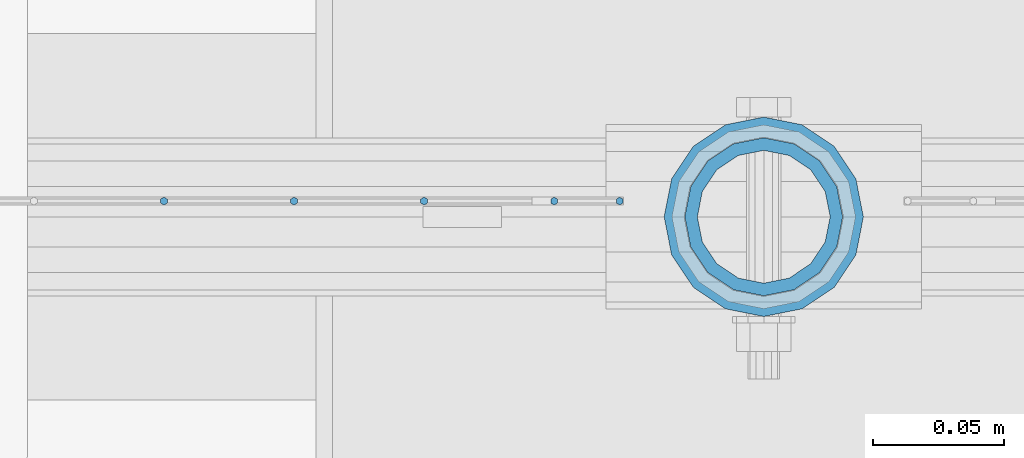
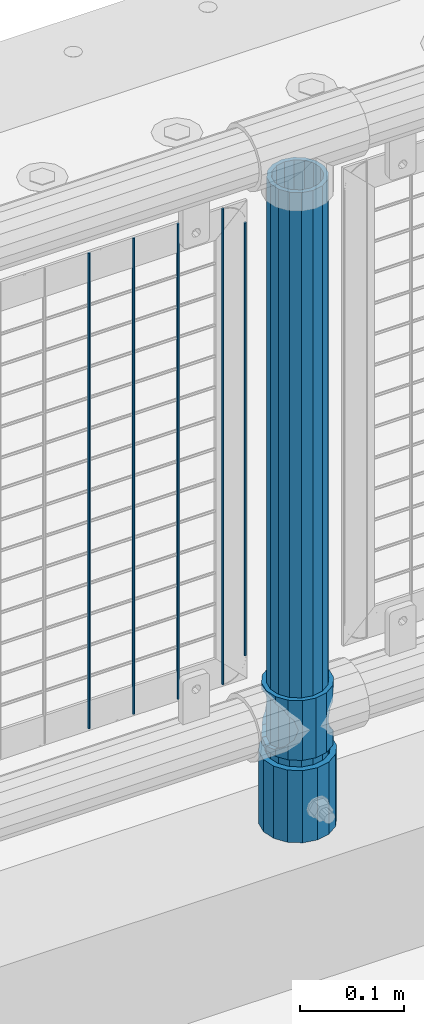
# One storey, part 57 of 208: 8 columns.
"""IFC2X3 building model written with IfcOpenShell, lengths in millimetres."""

from ifc_helpers import new_model, si_unit, frame, origin_with_axes, place, context, subcontext, project, spatial, faceted_brep, material, type_object, element, save


model = new_model("IFC2X3")

# Units and contexts
model_context = context("Model", 3, precision=1e-05, world=origin_with_axes())
body_context = subcontext(model_context, "Body", "Model", "MODEL_VIEW")
ifc_project = project(units=[si_unit("LENGTHUNIT", "METRE", prefix="MILLI"), si_unit("AREAUNIT", "SQUARE_METRE"), si_unit("VOLUMEUNIT", "CUBIC_METRE"), si_unit("MASSUNIT", "GRAM", prefix="KILO"), si_unit("TIMEUNIT", "SECOND"), si_unit("PLANEANGLEUNIT", "RADIAN"), si_unit("SOLIDANGLEUNIT", "STERADIAN"), si_unit("THERMODYNAMICTEMPERATUREUNIT", "DEGREE_CELSIUS"), si_unit("LUMINOUSINTENSITYUNIT", "LUMEN")], contexts=[model_context])

# Site, building, storey
site_placement = place(None, origin_with_axes())
site = spatial("IfcSite", under=ifc_project, at=site_placement, CompositionType="ELEMENT")
building_placement = place(site_placement, origin_with_axes())
building = spatial("IfcBuilding", under=site, at=building_placement, Name="Standard", CompositionType="ELEMENT")
storey_placement = place(building_placement, origin_with_axes())
storey = spatial("IfcBuildingStorey", under=building, at=storey_placement, Name="Undefined", CompositionType="ELEMENT", Elevation=0.0)

# Columns
ifc_material_1 = material()
column_type_1 = type_object("IfcColumnType", PredefinedType="NOTDEFINED")
column_1_placement = place(storey_placement, frame((-40229.0, 4664.5, 168.02), z_axis=(0.0, 1.0, 0.0), x_axis=(0.0, 0.0, 1.0)))
element("IfcColumn", 1, at=column_1_placement, inside=storey, type_object=column_type_1, material=ifc_material_1, context=body_context, shape_type="Brep", body=[
    faceted_brep([(0.0, -31.75, 0.0), (0.0, -29.3331751572332, 12.1501989775916), (85.0, -29.3331751572332, 12.1501989775916), (85.0, -31.75, 0.0), (0.0, -22.4506403026717, 22.4506403026726), (85.0, -22.4506403026717, 22.4506403026726), (0.0, -12.1501989775934, 29.3331751572332), (85.0, -12.1501989775934, 29.3331751572332), (0.0, 0.0, 31.75), (85.0, 0.0, 31.75), (0.0, 12.1501989775934, 29.3331751572332), (85.0, 12.1501989775934, 29.3331751572332), (0.0, 22.4506403026717, 22.4506403026726), (85.0, 22.4506403026717, 22.4506403026726), (0.0, 29.3331751572332, 12.1501989775916), (85.0, 29.3331751572332, 12.1501989775916), (0.0, 31.75, 0.0), (85.0, 31.75, 0.0), (0.0, 29.3331751572332, -12.1501989775916), (85.0, 29.3331751572332, -12.1501989775916), (0.0, 22.4506403026717, -22.4506403026726), (85.0, 22.4506403026717, -22.4506403026726), (0.0, 12.1501989775934, -29.3331751572332), (85.0, 12.1501989775934, -29.3331751572332), (0.0, 0.0, -31.75), (85.0, 0.0, -31.75), (0.0, -12.1501989775934, -29.3331751572332), (85.0, -12.1501989775934, -29.3331751572332), (0.0, -22.4506403026717, -22.4506403026726), (85.0, -22.4506403026717, -22.4506403026726), (0.0, -29.3331751572332, -12.1501989775916), (85.0, -29.3331751572332, -12.1501989775916), (0.0, -38.0499999999993, 0.0), (0.0, -35.1536162120537, -14.5611046014919), (85.0, -35.1536162120537, -14.5611046014919), (85.0, -38.0499999999993, 0.0), (0.0, -26.9054130241493, -26.9054130241484), (85.0, -26.9054130241493, -26.9054130241484), (0.0, -14.5611046014928, -35.1536162120547), (85.0, -14.5611046014928, -35.1536162120547), (0.0, 0.0, -38.0500000000002), (85.0, 0.0, -38.0500000000002), (0.0, 14.5611046014928, -35.1536162120547), (85.0, 14.5611046014928, -35.1536162120547), (0.0, 26.9054130241493, -26.9054130241484), (85.0, 26.9054130241493, -26.9054130241484), (0.0, 35.1536162120537, -14.5611046014919), (85.0, 35.1536162120537, -14.5611046014919), (0.0, 38.0499999999993, 0.0), (85.0, 38.0499999999993, 0.0), (0.0, 35.1536162120537, 14.5611046014919), (85.0, 35.1536162120537, 14.5611046014919), (0.0, 26.9054130241493, 26.9054130241484), (85.0, 26.9054130241493, 26.9054130241484), (0.0, 14.5611046014928, 35.1536162120547), (85.0, 14.5611046014928, 35.1536162120547), (0.0, 0.0, 38.0500000000002), (85.0, 0.0, 38.0500000000002), (0.0, -14.5611046014928, 35.1536162120547), (85.0, -14.5611046014928, 35.1536162120547), (0.0, -26.9054130241493, 26.9054130241484), (85.0, -26.9054130241493, 26.9054130241484), (0.0, -35.1536162120537, 14.5611046014919), (85.0, -35.1536162120537, 14.5611046014919)], [[[0, 1, 2, 3]], [[1, 4, 5, 2]], [[4, 6, 7, 5]], [[6, 8, 9, 7]], [[8, 10, 11, 9]], [[10, 12, 13, 11]], [[12, 14, 15, 13]], [[14, 16, 17, 15]], [[16, 18, 19, 17]], [[18, 20, 21, 19]], [[20, 22, 23, 21]], [[22, 24, 25, 23]], [[24, 26, 27, 25]], [[26, 28, 29, 27]], [[28, 30, 31, 29]], [[30, 0, 3, 31]], [[32, 33, 34, 35]], [[33, 36, 37, 34]], [[36, 38, 39, 37]], [[38, 40, 41, 39]], [[40, 42, 43, 41]], [[42, 44, 45, 43]], [[44, 46, 47, 45]], [[46, 48, 49, 47]], [[48, 50, 51, 49]], [[50, 52, 53, 51]], [[52, 54, 55, 53]], [[54, 56, 57, 55]], [[56, 58, 59, 57]], [[58, 60, 61, 59]], [[60, 62, 63, 61]], [[62, 32, 35, 63]], [[37, 39, 41, 43, 45, 47, 49, 51, 53, 55, 57, 59, 61, 63, 35, 34], [5, 7, 9, 11, 13, 15, 17, 19, 21, 23, 25, 27, 29, 31, 3, 2]], [[62, 60, 58, 56, 54, 52, 50, 48, 46, 44, 42, 40, 38, 36, 33, 32], [30, 28, 26, 24, 22, 20, 18, 16, 14, 12, 10, 8, 6, 4, 1, 0]]]),
])
ifc_material_2 = material(Name="Misc_Undefined")
column_type_2 = type_object("IfcColumnType", PredefinedType="NOTDEFINED")
column_2_placement = place(storey_placement, frame((-40229.0, 4664.5, 263.02), z_axis=(-1.0, 0.0, 0.0), x_axis=(0.0, 0.0, 1.0)))
element("IfcColumn", 2, at=column_2_placement, inside=storey, type_object=column_type_2, material=ifc_material_2, context=body_context, shape_type="Brep", body=[
    faceted_brep([(63.1897438117172, 11.6144421722802, -32.8397438117245), (63.1897438117172, 11.6144421722802, -28.0397438117143), (56.6106908090114, 21.4606908090118, -21.4606908090136), (56.6106908090114, 21.4606908090118, -27.1226768591077), (61.962379517676, 13.4513226476329, -32.4743655677739), (46.7644421722801, 28.0397438117179, -11.6144421722784), (46.7644421722801, 28.0397438117179, -20.0882031229921), (51.531042408003, 24.8548033587067, -24.8548033587067), (35.1500000000015, 30.35, 0.0), (35.1499999999996, 30.3500000000004, -16.6306603983685), (23.5355578277192, 28.0397438117179, -11.6144421722784), (23.5355578277192, 28.0397438117179, -20.0882031229921), (18.7689575919962, 24.8548033587067, -24.8548033587067), (13.6893091909879, 21.4606908090118, -21.4606908090136), (13.6893091909879, 21.4606908090118, -27.1226768591077), (8.33762048232325, 13.4513226476329, -32.4743655677739), (7.11025618828211, 11.6144421722802, -28.0397438117143), (7.11025618828211, 11.6144421722802, -32.8397438117245), (4.79999999999961, 0.0, -30.3499999999985), (4.79999999999961, 0.0, -35.1500000000015), (7.11025618828205, -11.6144421722802, -28.0397438117143), (7.11025618828205, -11.6144421722802, -32.8397438117245), (13.6893091909879, -21.4606908090118, -21.4606908090136), (13.6893091909879, -21.4606908090118, -27.1226768591005), (8.33762048232325, -13.4513226476329, -32.4743655677739), (23.5355578277191, -28.0397438117179, -11.6144421722784), (23.5355578277191, -28.0397438117179, -20.0882031229921), (18.7689575919962, -24.8548033587067, -24.8548033587067), (35.1500000000015, -30.35, 0.0), (35.1499999999996, -30.3500000000004, -16.6306603983685), (46.7644421722801, -28.0397438117179, -11.6144421722784), (46.7644421722801, -28.0397438117179, -20.0882031229921), (51.531042408003, -24.8548033587067, -24.8548033587067), (56.6106908090114, -21.4606908090118, -21.4606908090136), (56.6106908090114, -21.4606908090118, -27.1226768591005), (61.962379517675, -13.4513226476329, -32.4743655677739), (63.1897438117172, -11.6144421722802, -28.0397438117143), (63.1897438117172, -11.6144421722802, -32.8397438117245), (65.4999999999997, 0.0, -30.3499999999985), (65.4999999999997, 0.0, -35.1500000000015), (0.0, -28.0397438117179, -11.6144421722784), (0.0, -30.3500000000004, 0.0), (0.0, -21.4606908090118, -21.4606908090136), (0.0, -11.6144421722802, -28.0397438117143), (0.0, 0.0, -30.3499999999985), (0.0, 11.6144421722802, -28.0397438117143), (0.0, 21.4606908090118, -21.4606908090136), (0.0, 28.0397438117179, -11.6144421722784), (0.0, 30.3500000000004, 0.0), (0.0, 28.0397438117179, 11.6144421722784), (23.5355578277192, 28.0397438117179, 11.6144421722784), (0.0, 21.4606908090118, 21.4606908090136), (13.6893091909879, 21.4606908090118, 21.4606908090136), (0.0, 11.6144421722802, 28.0397438117143), (7.11025618828211, 11.6144421722802, 28.0397438117143), (0.0, 0.0, 30.3499999999985), (4.79999999999961, 0.0, 30.3499999999985), (0.0, -11.6144421722802, 28.0397438117143), (7.11025618828205, -11.6144421722802, 28.0397438117143), (0.0, -21.4606908090118, 21.4606908090136), (13.6893091909879, -21.4606908090118, 21.4606908090136), (0.0, -28.0397438117179, 11.6144421722784), (23.5355578277191, -28.0397438117179, 11.6144421722784), (0.0, -32.4743655677721, 13.4513226476338), (0.0, -35.1499999999996, 0.0), (70.2999999999993, -35.1499999999996, 0.0), (70.2999999999993, -32.4743655677721, 13.4513226476338), (0.0, 13.4513226476329, -32.4743655677739), (0.0, 24.8548033587067, -24.8548033587067), (0.0, 0.0, -35.1499999999996), (0.0, -13.4513226476329, -32.4743655677739), (0.0, -24.8548033587067, -24.8548033587067), (0.0, -24.8548033587067, 24.8548033587067), (0.0, -13.4513226476329, 32.4743655677739), (0.0, 0.0, 35.1499999999996), (0.0, 13.4513226476329, 32.4743655677739), (0.0, 24.8548033587067, 24.8548033587067), (0.0, 32.4743655677721, 13.4513226476338), (0.0, 35.1499999999996, 0.0), (0.0, 32.4743655677721, -13.4513226476338), (0.0, -32.4743655677721, -13.4513226476338), (70.2999999999993, 32.4743655677721, 13.4513226476338), (70.2999999999993, 35.1499999999996, 0.0), (70.2999999999993, 32.4743655677721, -13.4513226476338), (70.2999999999993, 24.8548033587067, -24.8548033587067), (70.2999999999993, 13.4513226476329, -32.4743655677739), (70.2999999999993, 0.0, -35.1500000000015), (70.2999999999993, -13.4513226476329, -32.4743655677739), (70.2999999999993, -24.8548033587067, -24.8548033587067), (70.2999999999993, -32.4743655677721, -13.4513226476338), (70.2999999999993, 28.0397438117179, 11.6144421722784), (70.2999999999993, 21.4606908090118, 21.4606908090136), (56.6106908090114, 21.4606908090118, 21.4606908090136), (46.7644421722801, 28.0397438117179, 11.6144421722784), (70.2999999999993, 11.6144421722802, 28.0397438117143), (63.1897438117172, 11.6144421722802, 28.0397438117143), (70.2999999999993, 0.0, 30.3499999999985), (65.4999999999997, 0.0, 30.3499999999985), (70.2999999999993, -11.6144421722802, 28.0397438117143), (63.1897438117172, -11.6144421722802, 28.0397438117143), (70.2999999999993, -21.4606908090118, 21.4606908090136), (56.6106908090114, -21.4606908090118, 21.4606908090136), (70.2999999999993, -28.0397438117179, 11.6144421722784), (46.7644421722801, -28.0397438117179, 11.6144421722784), (70.2999999999993, -11.6144421722802, -28.0397438117143), (70.2999999999993, 0.0, -30.3499999999985), (70.2999999999993, -21.4606908090118, -21.4606908090136), (70.2999999999993, -28.0397438117179, -11.6144421722784), (70.2999999999993, -30.3500000000004, 0.0), (70.2999999999993, 24.8548033587067, 24.8548033587067), (70.2999999999993, 13.4513226476329, 32.4743655677739), (70.2999999999993, 0.0, 35.1500000000015), (70.2999999999993, -13.4513226476329, 32.4743655677739), (70.2999999999993, -24.8548033587067, 24.8548033587067), (70.2999999999993, 30.3500000000004, 0.0), (70.2999999999993, 28.0397438117179, -11.6144421722784), (70.2999999999993, 21.4606908090118, -21.4606908090136), (70.2999999999993, 11.6144421722802, -28.0397438117143), (61.9623795176756, 13.4513226476329, 32.4743655677739), (51.531042408003, 24.8548033587067, 24.8548033587067), (56.6106908090114, 21.4606908090118, 27.1226768591005), (65.4999999999997, 0.0, 35.1500000000015), (63.1897438117172, 11.6144421722802, 32.8397438117172), (63.1897438117172, -11.6144421722802, 32.8397438117245), (61.962379517675, -13.4513226476329, 32.4743655677739), (56.6106908090114, -21.4606908090118, 27.1226768591077), (51.531042408003, -24.8548033587067, 24.8548033587067), (18.7689575919962, -24.8548033587067, 24.8548033587067), (46.7644421722801, -28.0397438117179, 20.0882031229776), (35.1499999999996, -30.3500000000004, 16.6306603983612), (23.5355578277191, -28.0397438117179, 20.0882031229776), (8.3376204823237, -13.4513226476329, 32.4743655677739), (13.6893091909879, -21.4606908090118, 27.1226768591077), (4.79999999999961, 0.0, 35.1500000000015), (7.11025618828205, -11.6144421722802, 32.8397438117245), (7.11025618828211, 11.6144421722802, 32.8397438117172), (8.3376204823237, 13.4513226476329, 32.4743655677739), (13.6893091909879, 21.4606908090118, 27.1226768591005), (18.7689575919962, 24.8548033587067, 24.8548033587067), (23.5355578277192, 28.0397438117179, 20.0882031229921), (35.1499999999996, 30.3500000000004, 16.6306603983685), (46.7644421722801, 28.0397438117179, 20.0882031229921)], [[[0, 1, 2, 3, 4]], [[3, 2, 5, 6, 7]], [[6, 5, 8, 9]], [[9, 8, 10, 11]], [[12, 11, 10, 13, 14]], [[15, 14, 13, 16, 17]], [[17, 16, 18, 19]], [[19, 18, 20, 21]], [[21, 20, 22, 23, 24]], [[23, 22, 25, 26, 27]], [[26, 25, 28, 29]], [[29, 28, 30, 31]], [[32, 31, 30, 33, 34]], [[35, 34, 33, 36, 37]], [[37, 36, 38, 39]], [[39, 38, 1, 0]], [[40, 41, 28, 25]], [[42, 40, 25, 22]], [[43, 42, 22, 20]], [[44, 43, 20, 18]], [[45, 44, 18, 16]], [[46, 45, 16, 13]], [[47, 46, 13, 10]], [[48, 47, 10, 8]], [[49, 48, 8, 50]], [[51, 49, 50, 52]], [[53, 51, 52, 54]], [[55, 53, 54, 56]], [[57, 55, 56, 58]], [[59, 57, 58, 60]], [[61, 59, 60, 62]], [[41, 61, 62, 28]], [[63, 64, 65, 66]], [[67, 68, 12, 14, 15]], [[69, 67, 15, 17, 19]], [[24, 70, 69, 19, 21]], [[27, 71, 70, 24, 23]], [[63, 72, 73, 74, 75, 76, 77, 78, 79, 68, 67, 69, 70, 71, 80, 64], [40, 42, 43, 44, 45, 46, 47, 48, 49, 51, 53, 55, 57, 59, 61, 41]], [[78, 77, 81, 82]], [[79, 78, 82, 83]], [[9, 11, 12, 68, 79, 83, 84, 7, 6]], [[7, 84, 85, 4, 3]], [[4, 85, 86, 39, 0]], [[87, 88, 32, 34, 35]], [[86, 87, 35, 37, 39]], [[88, 89, 80, 71, 27, 26, 29, 31, 32]], [[64, 80, 89, 65]], [[90, 91, 92, 93]], [[91, 94, 95, 92]], [[94, 96, 97, 95]], [[96, 98, 99, 97]], [[98, 100, 101, 99]], [[100, 102, 103, 101]], [[104, 105, 38, 36]], [[106, 104, 36, 33]], [[107, 106, 33, 30]], [[108, 107, 30, 28]], [[102, 108, 28, 103]], [[88, 87, 86, 85, 84, 83, 82, 81, 109, 110, 111, 112, 113, 66, 65, 89], [100, 98, 96, 94, 91, 90, 114, 115, 116, 117, 105, 104, 106, 107, 108, 102]], [[118, 110, 109, 119, 120]], [[121, 111, 110, 118, 122]], [[112, 111, 121, 123, 124]], [[113, 112, 124, 125, 126]], [[127, 72, 63, 66, 113, 126, 128, 129, 130]], [[131, 73, 72, 127, 132]], [[133, 74, 73, 131, 134]], [[75, 74, 133, 135, 136]], [[76, 75, 136, 137, 138]], [[119, 109, 81, 77, 76, 138, 139, 140, 141]], [[92, 120, 119, 141, 93]], [[95, 122, 118, 120, 92]], [[97, 121, 122, 95]], [[99, 123, 121, 97]], [[101, 125, 124, 123, 99]], [[103, 128, 126, 125, 101]], [[28, 129, 128, 103]], [[62, 130, 129, 28]], [[60, 132, 127, 130, 62]], [[58, 134, 131, 132, 60]], [[56, 133, 134, 58]], [[54, 135, 133, 56]], [[52, 137, 136, 135, 54]], [[50, 139, 138, 137, 52]], [[8, 140, 139, 50]], [[93, 141, 140, 8]], [[114, 90, 93, 8]], [[115, 114, 8, 5]], [[116, 115, 5, 2]], [[117, 116, 2, 1]], [[105, 117, 1, 38]]]),
])
column_type_3 = type_object("IfcColumnType", PredefinedType="NOTDEFINED")
column_3_placement = place(storey_placement, frame((-40229.0, 4664.5, 168.02), z_axis=(-1.0, 0.0, 0.0), x_axis=(0.0, 0.0, 1.0)))
element("IfcColumn", 3, at=column_3_placement, inside=storey, type_object=column_type_3, material=ifc_material_1, context=body_context, shape_type="Brep", body=[
    faceted_brep([(0.0, -25.3500000000004, 0.0), (0.0, -23.4203461491616, 9.70102501045403), (760.0, -23.4203461491616, 9.70102501045403), (760.0, -25.3500000000004, 0.0), (0.0, -17.9251569030794, 17.9251569030785), (760.0, -17.9251569030794, 17.9251569030785), (0.0, -9.70102501045494, 23.4203461491597), (760.0, -9.70102501045494, 23.4203461491597), (0.0, 0.0, 25.3499999999985), (760.0, 0.0, 25.3499999999985), (0.0, 9.70102501045494, 23.4203461491597), (760.0, 9.70102501045494, 23.4203461491597), (0.0, 17.9251569030794, 17.9251569030785), (760.0, 17.9251569030794, 17.9251569030785), (0.0, 23.4203461491616, 9.70102501045403), (760.0, 23.4203461491616, 9.70102501045403), (0.0, 25.3500000000004, 0.0), (760.0, 25.3500000000004, 0.0), (0.0, 23.4203461491616, -9.70102501045403), (760.0, 23.4203461491616, -9.70102501045403), (0.0, 17.9251569030794, -17.9251569030785), (760.0, 17.9251569030794, -17.9251569030785), (0.0, 9.70102501045494, -23.4203461491597), (760.0, 9.70102501045494, -23.4203461491597), (0.0, 0.0, -25.3499999999985), (760.0, 0.0, -25.3499999999985), (0.0, -9.70102501045494, -23.4203461491597), (760.0, -9.70102501045494, -23.4203461491597), (0.0, -17.9251569030794, -17.9251569030785), (760.0, -17.9251569030794, -17.9251569030785), (0.0, -23.4203461491616, -9.70102501045403), (760.0, -23.4203461491616, -9.70102501045403), (0.0, -30.1499999999996, 0.0), (0.0, -27.8549679052148, -11.5379054858058), (760.0, -27.8549679052148, -11.5379054858058), (760.0, -30.1499999999996, 0.0), (0.0, -21.3192694527743, -21.3192694527752), (760.0, -21.3192694527743, -21.3192694527752), (0.0, -11.5379054858076, -27.8549679052157), (760.0, -11.5379054858076, -27.8549679052157), (0.0, 0.0, -30.1500000000015), (760.0, 0.0, -30.1500000000015), (0.0, 11.5379054858076, -27.8549679052157), (760.0, 11.5379054858076, -27.8549679052157), (0.0, 21.3192694527743, -21.3192694527752), (760.0, 21.3192694527743, -21.3192694527752), (0.0, 27.8549679052157, -11.5379054858058), (760.0, 27.8549679052157, -11.5379054858058), (0.0, 30.1499999999996, 0.0), (760.0, 30.1499999999996, 0.0), (0.0, 27.8549679052157, 11.5379054858058), (760.0, 27.8549679052157, 11.5379054858058), (0.0, 21.3192694527743, 21.3192694527752), (760.0, 21.3192694527743, 21.3192694527752), (0.0, 11.5379054858076, 27.8549679052157), (760.0, 11.5379054858076, 27.8549679052157), (0.0, 0.0, 30.1500000000015), (760.0, 0.0, 30.1500000000015), (0.0, -11.5379054858076, 27.8549679052157), (760.0, -11.5379054858076, 27.8549679052157), (0.0, -21.3192694527743, 21.3192694527752), (760.0, -21.3192694527743, 21.3192694527752), (0.0, -27.8549679052157, 11.5379054858058), (760.0, -27.8549679052157, 11.5379054858058)], [[[0, 1, 2, 3]], [[1, 4, 5, 2]], [[4, 6, 7, 5]], [[6, 8, 9, 7]], [[8, 10, 11, 9]], [[10, 12, 13, 11]], [[12, 14, 15, 13]], [[14, 16, 17, 15]], [[16, 18, 19, 17]], [[18, 20, 21, 19]], [[20, 22, 23, 21]], [[22, 24, 25, 23]], [[24, 26, 27, 25]], [[26, 28, 29, 27]], [[28, 30, 31, 29]], [[30, 0, 3, 31]], [[32, 33, 34, 35]], [[33, 36, 37, 34]], [[36, 38, 39, 37]], [[38, 40, 41, 39]], [[40, 42, 43, 41]], [[42, 44, 45, 43]], [[44, 46, 47, 45]], [[46, 48, 49, 47]], [[48, 50, 51, 49]], [[50, 52, 53, 51]], [[52, 54, 55, 53]], [[54, 56, 57, 55]], [[56, 58, 59, 57]], [[58, 60, 61, 59]], [[60, 62, 63, 61]], [[62, 32, 35, 63]], [[37, 39, 41, 43, 45, 47, 49, 51, 53, 55, 57, 59, 61, 63, 35, 34], [5, 7, 9, 11, 13, 15, 17, 19, 21, 23, 25, 27, 29, 31, 3, 2]], [[62, 60, 58, 56, 54, 52, 50, 48, 46, 44, 42, 40, 38, 36, 33, 32], [30, 28, 26, 24, 22, 20, 18, 16, 14, 12, 10, 8, 6, 4, 1, 0]]]),
])
column_type_4 = type_object("IfcColumnType", Name="D3", PredefinedType="NOTDEFINED")
for number, where, z_axis, x_axis in (
    (4, (-40309.005, 4670.5, 353.02), (-1.0, 0.0, 0.0), (0.0, 0.0, 1.0)),
    (5, (-40358.66, 4670.5, 353.02), (-1.0, 0.0, 0.0), (0.0, 0.0, 1.0)),
    (6, (-40408.315, 4670.5, 353.02), (-1.0, 0.0, 0.0), (0.0, 0.0, 1.0)),
    (7, (-40457.97, 4670.5, 353.02), (-1.0, 0.0, 0.0), (0.0, 0.0, 1.0)),
):
    element("IfcColumn", number, at=place(storey_placement, frame(where, z_axis=z_axis, x_axis=x_axis)), inside=storey, type_object=column_type_4, material=ifc_material_2, ObjectType="D3", context=body_context, shape_type="Brep", body=[
        faceted_brep([(0.0, -1.49999999999909, 3.63797880709171e-12), (-7.27595761418343e-12, -0.749999999999091, -1.29903810567669), (560.0, -0.75, -1.29903810567703), (560.0, -1.5, 0.0), (-3.63797880709171e-12, 0.750000000000909, -1.29903810567669), (560.0, 0.75, -1.29903810567703), (0.0, 1.50000000000182, 3.63797880709171e-12), (560.0, 1.5, 0.0), (-3.63797880709171e-12, 0.750000000000909, 1.29903810567669), (560.0, 0.75, 1.29903810567703), (-7.27595761418343e-12, -0.749999999999091, 1.29903810567669), (560.0, -0.75, 1.29903810567703)], [[[0, 1, 2, 3]], [[1, 4, 5, 2]], [[4, 6, 7, 5]], [[6, 8, 9, 7]], [[8, 10, 11, 9]], [[10, 0, 3, 11]], [[5, 7, 9, 11, 3, 2]], [[10, 8, 6, 4, 1, 0]]]),
    ])
column_4_placement = place(storey_placement, frame((-40284.0, 4670.5, 378.02), z_axis=(-1.0, 0.0, 0.0), x_axis=(0.0, 0.0, 1.0)))
element("IfcColumn", 8, at=column_4_placement, inside=storey, type_object=column_type_4, material=ifc_material_2, ObjectType="D3", context=body_context, shape_type="Brep", body=[
    faceted_brep([(0.0, -1.49999999999909, 3.63797880709171e-12), (-7.27595761418343e-12, -0.749999999999091, -1.29903810567669), (510.0, -0.75, -1.29903810567703), (510.0, -1.5, 0.0), (-3.63797880709171e-12, 0.750000000000909, -1.29903810567669), (510.0, 0.75, -1.29903810567703), (0.0, 1.50000000000182, 3.63797880709171e-12), (510.0, 1.5, 0.0), (-3.63797880709171e-12, 0.750000000000909, 1.29903810567669), (510.0, 0.75, 1.29903810567703), (-7.27595761418343e-12, -0.749999999999091, 1.29903810567669), (510.0, -0.75, 1.29903810567703)], [[[0, 1, 2, 3]], [[1, 4, 5, 2]], [[4, 6, 7, 5]], [[6, 8, 9, 7]], [[8, 10, 11, 9]], [[10, 0, 3, 11]], [[5, 7, 9, 11, 3, 2]], [[10, 8, 6, 4, 1, 0]]]),
])

save(model, "model.ifc")
